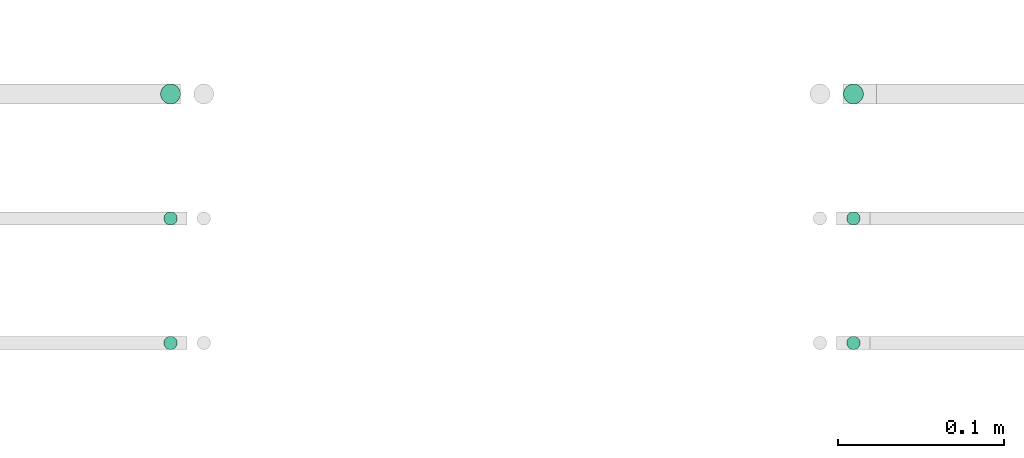
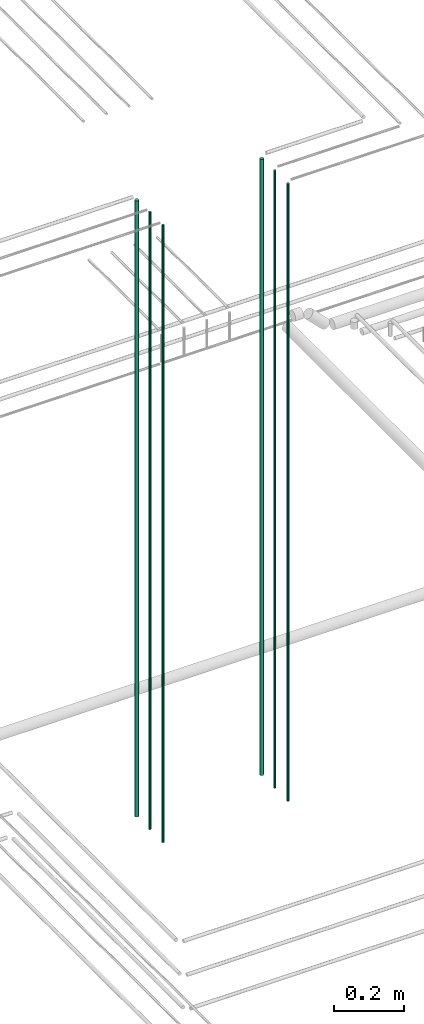
# One storey, part 5 of 331: 6 flow segments.
"""IFC2X3 building model written with IfcOpenShell, lengths in millimetres."""

from ifc_helpers import new_model, entity, si_unit, converted_unit, derived_unit, direction, frame, origin, origin_2d_with_axis, place, context, subcontext, project, spatial, circle, extrude, type_object, element, save


model = new_model("IFC2X3")

# Units and contexts
model_context = context("Model", 3, precision=0.01, world=origin(), true_north=direction((6.12303176911189e-17, 1.0)))
body_context = subcontext(model_context, "Body", "Model", "MODEL_VIEW")
ifc_project = project(units=[si_unit("LENGTHUNIT", "METRE", prefix="MILLI"), si_unit("AREAUNIT", "SQUARE_METRE"), si_unit("VOLUMEUNIT", "CUBIC_METRE"), converted_unit("PLANEANGLEUNIT", "DEGREE", entity("IfcRatioMeasure", 0.0174532925199433), si_unit("PLANEANGLEUNIT", "RADIAN"), dimensions=[0, 0, 0, 0, 0, 0, 0]), si_unit("MASSUNIT", "GRAM", prefix="KILO"), derived_unit("MASSDENSITYUNIT", [(si_unit("MASSUNIT", "GRAM", prefix="KILO"), 1), (si_unit("LENGTHUNIT", "METRE"), -3)]), derived_unit("MOMENTOFINERTIAUNIT", [(si_unit("LENGTHUNIT", "METRE"), 4)]), si_unit("TIMEUNIT", "SECOND"), si_unit("FREQUENCYUNIT", "HERTZ"), si_unit("THERMODYNAMICTEMPERATUREUNIT", "DEGREE_CELSIUS"), derived_unit("THERMALTRANSMITTANCEUNIT", [(si_unit("MASSUNIT", "GRAM", prefix="KILO"), 1), (si_unit("THERMODYNAMICTEMPERATUREUNIT", "KELVIN"), -1), (si_unit("TIMEUNIT", "SECOND"), -3)]), derived_unit("VOLUMETRICFLOWRATEUNIT", [(si_unit("LENGTHUNIT", "METRE"), 3), (si_unit("TIMEUNIT", "SECOND"), -1)]), derived_unit("MASSFLOWRATEUNIT", [(si_unit("MASSUNIT", "GRAM", prefix="KILO"), 1), (si_unit("TIMEUNIT", "SECOND"), -1)]), derived_unit("ROTATIONALFREQUENCYUNIT", [(si_unit("TIMEUNIT", "SECOND"), -1)]), si_unit("ELECTRICCURRENTUNIT", "AMPERE"), si_unit("ELECTRICVOLTAGEUNIT", "VOLT"), si_unit("POWERUNIT", "WATT"), si_unit("FORCEUNIT", "NEWTON", prefix="KILO"), si_unit("ILLUMINANCEUNIT", "LUX"), si_unit("LUMINOUSFLUXUNIT", "LUMEN"), si_unit("LUMINOUSINTENSITYUNIT", "CANDELA"), derived_unit("USERDEFINED", [(si_unit("MASSUNIT", "GRAM", prefix="KILO"), -1), (si_unit("LENGTHUNIT", "METRE"), -2), (si_unit("TIMEUNIT", "SECOND"), 3), (si_unit("LUMINOUSFLUXUNIT", "LUMEN"), 1)]), derived_unit("LINEARVELOCITYUNIT", [(si_unit("LENGTHUNIT", "METRE"), 1), (si_unit("TIMEUNIT", "SECOND"), -1)]), si_unit("PRESSUREUNIT", "PASCAL"), derived_unit("USERDEFINED", [(si_unit("LENGTHUNIT", "METRE"), -2), (si_unit("MASSUNIT", "GRAM", prefix="KILO"), 1), (si_unit("TIMEUNIT", "SECOND"), -2)]), derived_unit("LINEARFORCEUNIT", [(si_unit("MASSUNIT", "GRAM", prefix="KILO"), 1), (si_unit("LENGTHUNIT", "METRE"), 1), (si_unit("TIMEUNIT", "SECOND"), -2), (si_unit("LENGTHUNIT", "METRE"), -1)]), derived_unit("PLANARFORCEUNIT", [(si_unit("MASSUNIT", "GRAM", prefix="KILO"), 1), (si_unit("LENGTHUNIT", "METRE"), 1), (si_unit("TIMEUNIT", "SECOND"), -2), (si_unit("LENGTHUNIT", "METRE"), -2)])], contexts=[model_context])

# Site, building, storey
site_placement = place(None, frame((0.0, -0.00077364408347762, 0.0)))
site = spatial("IfcSite", under=ifc_project, at=site_placement, CompositionType="ELEMENT")
building_placement = place(site_placement, origin())
building = spatial("IfcBuilding", under=site, at=building_placement, CompositionType="ELEMENT")
storey_placement = place(building_placement, origin())
storey = spatial("IfcBuildingStorey", under=building, at=storey_placement, CompositionType="ELEMENT", Elevation=0.0)

# Flow segments
pipe_segment_type = type_object("IfcPipeSegmentType", PredefinedType="NOTDEFINED")
flow_segment_1_placement = place(storey_placement, frame((25969.3494489383, 1343.89349484378, 16890.0)))
element("IfcFlowSegment", 1, at=flow_segment_1_placement, inside=storey, type_object=pipe_segment_type, context=body_context, shape_type="SweptSolid", body=[
    extrude(circle(Radius=6.0, at=origin_2d_with_axis()), frame((7.59527223591454, 7.59527223591589, 0.0)), (0.0, 0.0, 1.0), 2146.0),
])
flow_segment_2_placement = place(storey_placement, frame((25971.3494489383, 1270.89349484379, 16890.0)))
element("IfcFlowSegment", 2, at=flow_segment_2_placement, inside=storey, type_object=pipe_segment_type, context=body_context, shape_type="SweptSolid", body=[
    extrude(circle(Radius=4.0, at=origin_2d_with_axis()), frame((5.59527223591499, 5.5952722359158, 0.0)), (0.0, 0.0, 1.0), 2150.00000000001),
])
flow_segment_3_placement = place(storey_placement, frame((25971.3494489383, 1195.89349484378, 16890.0)))
element("IfcFlowSegment", 3, at=flow_segment_3_placement, inside=storey, type_object=pipe_segment_type, context=body_context, shape_type="SweptSolid", body=[
    extrude(circle(Radius=4.0, at=origin_2d_with_axis()), frame((5.59527223591499, 5.59527223591607, 0.0)), (0.0, 0.0, 1.0), 2150.00000000001),
])
flow_segment_4_placement = place(storey_placement, frame((25557.8400885059, 1343.89349484382, 16890.0)))
element("IfcFlowSegment", 4, at=flow_segment_4_placement, inside=storey, type_object=pipe_segment_type, context=body_context, shape_type="SweptSolid", body=[
    extrude(circle(Radius=6.0, at=origin_2d_with_axis()), frame((7.59527223591454, 7.59527223591589, 0.0)), (0.0, 0.0, 1.0), 2146.00000000001),
])
flow_segment_5_placement = place(storey_placement, frame((25559.8400885059, 1270.89349484381, 16890.0)))
element("IfcFlowSegment", 5, at=flow_segment_5_placement, inside=storey, type_object=pipe_segment_type, context=body_context, shape_type="SweptSolid", body=[
    extrude(circle(Radius=4.0, at=origin_2d_with_axis()), frame((5.59527223591499, 5.5952722359158, 0.0)), (0.0, 0.0, 1.0), 2150.00000000001),
])
flow_segment_6_placement = place(storey_placement, frame((25559.8400885059, 1195.89349484378, 16890.0)))
element("IfcFlowSegment", 6, at=flow_segment_6_placement, inside=storey, type_object=pipe_segment_type, context=body_context, shape_type="SweptSolid", body=[
    extrude(circle(Radius=4.0, at=origin_2d_with_axis()), frame((5.59527223591499, 5.59527223591607, 0.0)), (0.0, 0.0, 1.0), 2150.00000000001),
])

save(model, "model.ifc")
